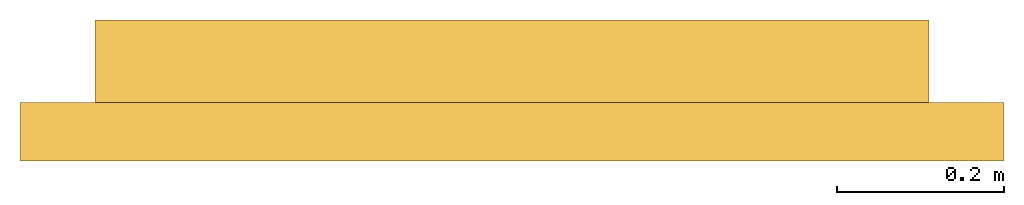
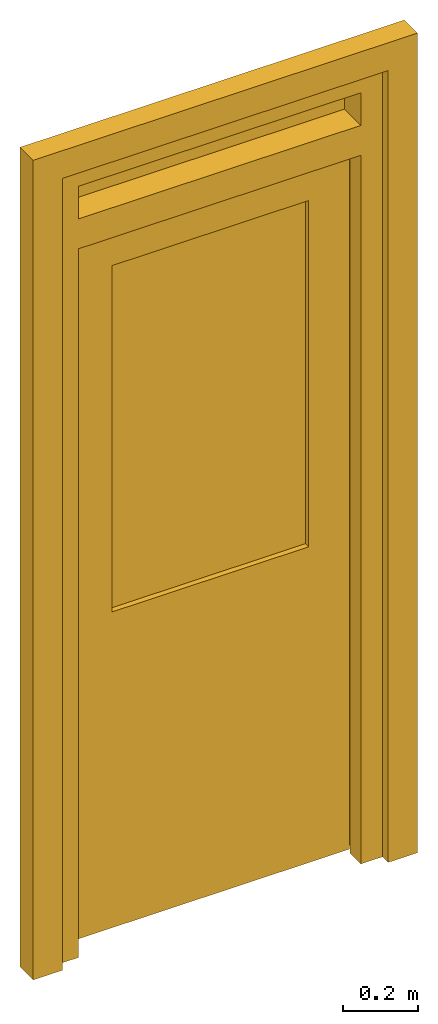
# One storey: 2 doors.
"""IFC4 building model written with IfcOpenShell, lengths in millimetres."""

from ifc_helpers import new_model, entity, si_unit, converted_unit, frame, origin_with_axes, origin_2d_with_axis, place, context, subcontext, project, spatial, polygons, source, transform, mapped, type_object, type_shapes, element, save


model = new_model("IFC4")

# Units and contexts
model_context = context("Model", 3, precision=1e-05, world=origin_with_axes())
plan_context = context("Plan", 2, precision=1e-05, world=origin_2d_with_axis())
body_context = subcontext(model_context, "Body", "Model", "MODEL_VIEW")
ifc_project = project(units=[si_unit("VOLUMEUNIT", "CUBIC_METRE"), si_unit("LENGTHUNIT", "METRE", prefix="MILLI"), converted_unit("PLANEANGLEUNIT", "degree", entity("IfcReal", 0.0174532925199433), si_unit("PLANEANGLEUNIT", "RADIAN"), dimensions=[0, 0, 0, 0, 0, 0, 0]), si_unit("AREAUNIT", "SQUARE_METRE")], contexts=[model_context, plan_context])

# Site, building, storey
site_placement = place(None, origin_with_axes())
site = spatial("IfcSite", under=ifc_project, at=site_placement)
building_placement = place(site_placement, origin_with_axes())
building = spatial("IfcBuilding", under=site, at=building_placement, Name="Building")
storey_placement = place(building_placement, origin_with_axes())
storey = spatial("IfcBuildingStorey", under=building, at=storey_placement, Name="Storey")

# Doors
door_type_1 = type_object("IfcDoorType", Name="D-1000x2570 T", OperationType="NOTDEFINED", PredefinedType="DOOR")
shared_shape_1 = source(origin_with_axes(), body_context, "Body", "Tessellation", [
    polygons([(-933.000061035156, -138.999938964844, -6.07588299317285e-06), (-1000.00006103516, -138.999938964844, -6.07588299317285e-06), (-933.000061035156, -139.000061035156, 2300.0), (-67.0000305175781, -139.000061035156, 2300.0), (-67.0000305175781, -138.999938964844, -6.07588299317285e-06), (0.0, -138.999938964844, -6.07588299317285e-06), (0.0, -139.000061035156, 2396.99975585938), (-1000.00006103516, -139.000061035156, 2396.99975585938), (-950.000122070312, 4.73394320579246e-05, 1.15221078663373e-13), (-950.000122070312, -4.73394320579246e-05, 2316.99951171875), (-1000.00006103516, 5.02680923091248e-05, 2.43237044004682e-13), (-1000.00006103516, -5.02680923091248e-05, 2396.99975585938), (0.0, -5.02680923091248e-05, 2396.99975585938), (0.0, 5.02680923091248e-05, 2.43237044004682e-13), (-50.0000686645508, 4.73394320579246e-05, 1.15221078663373e-13), (-50.0000686645508, -4.73394393338822e-05, 2233.00024414062), (-50.0000686645508, -4.73394320579246e-05, 2316.99951171875), (-933.000061035156, -4.73394320579246e-05, 2316.99951171875), (-933.000061035156, -82.0000457763672, 2300.0), (-67.0000305175781, -82.0000457763672, 2300.0), (-933.000061035156, -82.0000457763672, -3.58433749170217e-06), (-950.000122070312, -82.0000457763672, -3.58433749170217e-06), (-67.0000305175781, -82.0000457763672, -3.58433749170217e-06), (-50.0000686645508, -82.0000457763672, -3.58433749170217e-06), (-950.000122070312, -82.0000457763672, 2316.99951171875), (-933.000061035156, -82.0000457763672, 2316.99951171875), (-50.0000686645508, -82.0000457763672, 2316.99951171875), (-50.0000686645508, -82.0000457763672, 2233.00024414062), (-198.000061035156, -34.9999504089355, 1044.99987792969), (-198.000061035156, -88.9999542236328, 1044.99987792969), (-198.000061035156, -89.0000305175781, 2168.99975585938), (-198.000061035156, -35.0000381469727, 2168.99975585938), (-56.0000495910645, -74.0000381469727, 2310.0), (-56.0000495910645, -35.0000419616699, 2310.0), (-944.0, -35.0000419616699, 2310.0), (-944.0, -74.0000381469727, 2310.0), (-56.0000495910645, -73.9999465942383, 19.9999732971191), (-56.0000495910645, -34.9999465942383, 19.9999752044678), (-944.0, -34.9999465942383, 19.9999752044678), (-944.0, -73.9999465942383, 19.9999732971191), (-927.000061035156, -73.9999465942383, 19.9999732971191), (-927.000061035156, -74.0000381469727, 2293.0), (-73.0000686645508, -74.0000381469727, 2293.0), (-73.0000686645508, -73.9999465942383, 19.9999732971191), (-802.000061035156, -34.9999504089355, 1044.99987792969), (-802.000061035156, -88.9999542236328, 1044.99987792969), (-73.0000686645508, -88.9999465942383, 19.9999732971191), (-73.0000686645508, -89.0000381469727, 2293.0), (-927.000061035156, -89.0000381469727, 2293.0), (-927.000061035156, -88.9999465942383, 19.9999732971191), (-802.000061035156, -89.0000305175781, 2168.99975585938), (-802.000061035156, -35.0000381469727, 2168.99975585938), (-802.000061035156, -51.9999313354492, 1044.99987792969), (-198.000061035156, -51.9999313354492, 1044.99987792969), (-802.000061035156, -51.9999618530273, 2198.99975585938), (-198.000061035156, -51.9999618530273, 2198.99975585938), (-802.000061035156, -71.9999542236328, 2198.99975585938), (-802.000061035156, -71.9999237060547, 1044.99987792969), (-198.000061035156, -71.9999237060547, 1044.99987792969), (-198.000061035156, -71.9999542236328, 2198.99975585938), (-1000.00006103516, 0.0, 2396.99975585938), (-933.000061035156, 0.0, 2396.99975585938), (-1000.00006103516, 0.0, 2502.99975585938), (-933.000061035156, 0.0, 2502.99975585938), (-1000.00006103516, -139.000061035156, 2502.99975585938), (-1000.00006103516, -139.000061035156, 2396.99975585938), (-933.000061035156, -139.000061035156, 2396.99975585938), (-933.000061035156, -139.000061035156, 2502.99975585938), (-933.000061035156, 0.0, 2569.99975585938), (-1000.00006103516, 0.0, 2569.99975585938), (-933.000061035156, -139.000061035156, 2569.99975585938), (-1000.00006103516, -139.000061035156, 2569.99975585938), (0.0, -139.000061035156, 2502.99975585938), (0.0, 0.0, 2502.99975585938), (0.0, -139.000061035156, 2569.99975585938), (0.0, 0.0, 2569.99975585938), (0.0, 0.0, 2502.99975585938), (-67.0000305175781, 0.0, 2502.99975585938), (0.0, -139.000061035156, 2502.99975585938), (-67.0000305175781, -139.000061035156, 2502.99975585938), (0.0, 0.0, 2396.99975585938), (-67.0000305175781, 0.0, 2396.99975585938), (0.0, -139.000061035156, 2396.99975585938), (-67.0000305175781, -139.000061035156, 2396.99975585938), (-933.000061035156, -31.9999580383301, 2396.99975585938), (-67.0000305175781, -31.9999580383301, 2396.99975585938), (-933.000061035156, -31.9999580383301, 2502.99975585938), (-67.0000305175781, -31.9999580383301, 2502.99975585938), (-933.000061035156, -51.9999694824219, 2502.99975585938), (-933.000061035156, -51.9999694824219, 2396.99975585938), (-67.0000305175781, -51.9999694824219, 2396.99975585938), (-67.0000305175781, -51.9999694824219, 2502.99975585938)], [[[6, 5, 23, 24, 15, 14]], [[6, 7, 8, 2, 1, 3, 4, 5]], [[4, 3, 19, 20]], [[17, 18, 10, 9, 11, 12, 13, 14, 15, 16]], [[2, 11, 9, 22, 21, 1]], [[4, 20, 23, 5]], [[12, 8, 7, 13]], [[22, 25, 26, 27, 28, 24, 23, 20, 19, 21]], [[18, 17, 27, 26, 25, 10]], [[13, 7, 6, 14]], [[16, 15, 24, 28, 27, 17]], [[9, 10, 25, 22]], [[1, 21, 19, 3]], [[12, 11, 2, 8]], [[61, 63, 64, 62]], [[66, 67, 68, 65]], [[61, 62, 67, 66]], [[62, 64, 68, 67]], [[63, 61, 66, 65]], [[63, 65, 72, 70]], [[69, 70, 72, 71, 75, 76]], [[73, 74, 76, 75]], [[77, 79, 80, 78]], [[81, 82, 84, 83]], [[78, 80, 84, 82]], [[77, 78, 82, 81]], [[79, 77, 81, 83]], [[80, 79, 83, 84]], [[68, 73, 75, 71, 72, 65]], [[64, 63, 70, 69, 76, 74]], [[64, 74, 73, 68, 65, 63]], [[73, 65, 68]], [[63, 74, 64]], [[86, 88, 92, 91]], [[87, 85, 90, 89]], [[88, 87, 89, 92]], [[85, 86, 91, 90]]], closed=False),
    polygons([(-933.000061035156, -138.999938964844, -6.07588299317285e-06), (-1000.00006103516, -138.999938964844, -6.07588299317285e-06), (-933.000061035156, -139.000061035156, 2300.0), (-67.0000305175781, -139.000061035156, 2300.0), (-67.0000305175781, -138.999938964844, -6.07588299317285e-06), (0.0, -138.999938964844, -6.07588299317285e-06), (0.0, -139.000061035156, 2396.99975585938), (-1000.00006103516, -139.000061035156, 2396.99975585938), (-950.000122070312, 4.73394320579246e-05, 1.15221078663373e-13), (-950.000122070312, -4.73394320579246e-05, 2316.99951171875), (-1000.00006103516, 5.02680923091248e-05, 2.43237044004682e-13), (-1000.00006103516, -5.02680923091248e-05, 2396.99975585938), (0.0, -5.02680923091248e-05, 2396.99975585938), (0.0, 5.02680923091248e-05, 2.43237044004682e-13), (-50.0000686645508, 4.73394320579246e-05, 1.15221078663373e-13), (-50.0000686645508, -4.73394393338822e-05, 2233.00024414062), (-50.0000686645508, -4.73394320579246e-05, 2316.99951171875), (-933.000061035156, -4.73394320579246e-05, 2316.99951171875), (-933.000061035156, -82.0000457763672, 2300.0), (-67.0000305175781, -82.0000457763672, 2300.0), (-933.000061035156, -82.0000457763672, -3.58433749170217e-06), (-950.000122070312, -82.0000457763672, -3.58433749170217e-06), (-67.0000305175781, -82.0000457763672, -3.58433749170217e-06), (-50.0000686645508, -82.0000457763672, -3.58433749170217e-06), (-950.000122070312, -82.0000457763672, 2316.99951171875), (-933.000061035156, -82.0000457763672, 2316.99951171875), (-50.0000686645508, -82.0000457763672, 2316.99951171875), (-50.0000686645508, -82.0000457763672, 2233.00024414062), (-198.000061035156, -34.9999504089355, 1044.99987792969), (-198.000061035156, -88.9999542236328, 1044.99987792969), (-198.000061035156, -89.0000305175781, 2168.99975585938), (-198.000061035156, -35.0000381469727, 2168.99975585938), (-56.0000495910645, -74.0000381469727, 2310.0), (-56.0000495910645, -35.0000419616699, 2310.0), (-944.0, -35.0000419616699, 2310.0), (-944.0, -74.0000381469727, 2310.0), (-56.0000495910645, -73.9999465942383, 19.9999732971191), (-56.0000495910645, -34.9999465942383, 19.9999752044678), (-944.0, -34.9999465942383, 19.9999752044678), (-944.0, -73.9999465942383, 19.9999732971191), (-927.000061035156, -73.9999465942383, 19.9999732971191), (-927.000061035156, -74.0000381469727, 2293.0), (-73.0000686645508, -74.0000381469727, 2293.0), (-73.0000686645508, -73.9999465942383, 19.9999732971191), (-802.000061035156, -34.9999504089355, 1044.99987792969), (-802.000061035156, -88.9999542236328, 1044.99987792969), (-73.0000686645508, -88.9999465942383, 19.9999732971191), (-73.0000686645508, -89.0000381469727, 2293.0), (-927.000061035156, -89.0000381469727, 2293.0), (-927.000061035156, -88.9999465942383, 19.9999732971191), (-802.000061035156, -89.0000305175781, 2168.99975585938), (-802.000061035156, -35.0000381469727, 2168.99975585938), (-802.000061035156, -51.9999313354492, 1044.99987792969), (-198.000061035156, -51.9999313354492, 1044.99987792969), (-802.000061035156, -51.9999618530273, 2198.99975585938), (-198.000061035156, -51.9999618530273, 2198.99975585938), (-802.000061035156, -71.9999542236328, 2198.99975585938), (-802.000061035156, -71.9999237060547, 1044.99987792969), (-198.000061035156, -71.9999237060547, 1044.99987792969), (-198.000061035156, -71.9999542236328, 2198.99975585938), (-1000.00006103516, 0.0, 2396.99975585938), (-933.000061035156, 0.0, 2396.99975585938), (-1000.00006103516, 0.0, 2502.99975585938), (-933.000061035156, 0.0, 2502.99975585938), (-1000.00006103516, -139.000061035156, 2502.99975585938), (-1000.00006103516, -139.000061035156, 2396.99975585938), (-933.000061035156, -139.000061035156, 2396.99975585938), (-933.000061035156, -139.000061035156, 2502.99975585938), (-933.000061035156, 0.0, 2569.99975585938), (-1000.00006103516, 0.0, 2569.99975585938), (-933.000061035156, -139.000061035156, 2569.99975585938), (-1000.00006103516, -139.000061035156, 2569.99975585938), (0.0, -139.000061035156, 2502.99975585938), (0.0, 0.0, 2502.99975585938), (0.0, -139.000061035156, 2569.99975585938), (0.0, 0.0, 2569.99975585938), (0.0, 0.0, 2502.99975585938), (-67.0000305175781, 0.0, 2502.99975585938), (0.0, -139.000061035156, 2502.99975585938), (-67.0000305175781, -139.000061035156, 2502.99975585938), (0.0, 0.0, 2396.99975585938), (-67.0000305175781, 0.0, 2396.99975585938), (0.0, -139.000061035156, 2396.99975585938), (-67.0000305175781, -139.000061035156, 2396.99975585938), (-933.000061035156, -31.9999580383301, 2396.99975585938), (-67.0000305175781, -31.9999580383301, 2396.99975585938), (-933.000061035156, -31.9999580383301, 2502.99975585938), (-67.0000305175781, -31.9999580383301, 2502.99975585938), (-933.000061035156, -51.9999694824219, 2502.99975585938), (-933.000061035156, -51.9999694824219, 2396.99975585938), (-67.0000305175781, -51.9999694824219, 2396.99975585938), (-67.0000305175781, -51.9999694824219, 2502.99975585938)], [[[51, 46, 45, 52]], [[40, 39, 38, 37, 44, 47, 50, 41]], [[31, 32, 29, 30]], [[31, 48, 49, 51]], [[34, 32, 52, 35]], [[36, 35, 39, 40]], [[36, 33, 34, 35]], [[34, 33, 37, 38]], [[41, 42, 36, 40]], [[43, 48, 47, 44]], [[49, 48, 43, 42]], [[30, 29, 45, 46]], [[37, 33, 43, 44]], [[46, 51, 49, 50, 47, 48, 31, 30]], [[49, 42, 41, 50]], [[43, 33, 36, 42]], [[34, 38, 39, 35, 52, 45, 29, 32]], [[31, 51, 52, 32]]], closed=False),
    polygons([(-933.000061035156, -138.999938964844, -6.07588299317285e-06), (-1000.00006103516, -138.999938964844, -6.07588299317285e-06), (-933.000061035156, -139.000061035156, 2300.0), (-67.0000305175781, -139.000061035156, 2300.0), (-67.0000305175781, -138.999938964844, -6.07588299317285e-06), (0.0, -138.999938964844, -6.07588299317285e-06), (0.0, -139.000061035156, 2396.99975585938), (-1000.00006103516, -139.000061035156, 2396.99975585938), (-950.000122070312, 4.73394320579246e-05, 1.15221078663373e-13), (-950.000122070312, -4.73394320579246e-05, 2316.99951171875), (-1000.00006103516, 5.02680923091248e-05, 2.43237044004682e-13), (-1000.00006103516, -5.02680923091248e-05, 2396.99975585938), (0.0, -5.02680923091248e-05, 2396.99975585938), (0.0, 5.02680923091248e-05, 2.43237044004682e-13), (-50.0000686645508, 4.73394320579246e-05, 1.15221078663373e-13), (-50.0000686645508, -4.73394393338822e-05, 2233.00024414062), (-50.0000686645508, -4.73394320579246e-05, 2316.99951171875), (-933.000061035156, -4.73394320579246e-05, 2316.99951171875), (-933.000061035156, -82.0000457763672, 2300.0), (-67.0000305175781, -82.0000457763672, 2300.0), (-933.000061035156, -82.0000457763672, -3.58433749170217e-06), (-950.000122070312, -82.0000457763672, -3.58433749170217e-06), (-67.0000305175781, -82.0000457763672, -3.58433749170217e-06), (-50.0000686645508, -82.0000457763672, -3.58433749170217e-06), (-950.000122070312, -82.0000457763672, 2316.99951171875), (-933.000061035156, -82.0000457763672, 2316.99951171875), (-50.0000686645508, -82.0000457763672, 2316.99951171875), (-50.0000686645508, -82.0000457763672, 2233.00024414062), (-198.000061035156, -34.9999504089355, 1044.99987792969), (-198.000061035156, -88.9999542236328, 1044.99987792969), (-198.000061035156, -89.0000305175781, 2168.99975585938), (-198.000061035156, -35.0000381469727, 2168.99975585938), (-56.0000495910645, -74.0000381469727, 2310.0), (-56.0000495910645, -35.0000419616699, 2310.0), (-944.0, -35.0000419616699, 2310.0), (-944.0, -74.0000381469727, 2310.0), (-56.0000495910645, -73.9999465942383, 19.9999732971191), (-56.0000495910645, -34.9999465942383, 19.9999752044678), (-944.0, -34.9999465942383, 19.9999752044678), (-944.0, -73.9999465942383, 19.9999732971191), (-927.000061035156, -73.9999465942383, 19.9999732971191), (-927.000061035156, -74.0000381469727, 2293.0), (-73.0000686645508, -74.0000381469727, 2293.0), (-73.0000686645508, -73.9999465942383, 19.9999732971191), (-802.000061035156, -34.9999504089355, 1044.99987792969), (-802.000061035156, -88.9999542236328, 1044.99987792969), (-73.0000686645508, -88.9999465942383, 19.9999732971191), (-73.0000686645508, -89.0000381469727, 2293.0), (-927.000061035156, -89.0000381469727, 2293.0), (-927.000061035156, -88.9999465942383, 19.9999732971191), (-802.000061035156, -89.0000305175781, 2168.99975585938), (-802.000061035156, -35.0000381469727, 2168.99975585938), (-802.000061035156, -51.9999313354492, 1044.99987792969), (-198.000061035156, -51.9999313354492, 1044.99987792969), (-802.000061035156, -51.9999618530273, 2198.99975585938), (-198.000061035156, -51.9999618530273, 2198.99975585938), (-802.000061035156, -71.9999542236328, 2198.99975585938), (-802.000061035156, -71.9999237060547, 1044.99987792969), (-198.000061035156, -71.9999237060547, 1044.99987792969), (-198.000061035156, -71.9999542236328, 2198.99975585938), (-1000.00006103516, 0.0, 2396.99975585938), (-933.000061035156, 0.0, 2396.99975585938), (-1000.00006103516, 0.0, 2502.99975585938), (-933.000061035156, 0.0, 2502.99975585938), (-1000.00006103516, -139.000061035156, 2502.99975585938), (-1000.00006103516, -139.000061035156, 2396.99975585938), (-933.000061035156, -139.000061035156, 2396.99975585938), (-933.000061035156, -139.000061035156, 2502.99975585938), (-933.000061035156, 0.0, 2569.99975585938), (-1000.00006103516, 0.0, 2569.99975585938), (-933.000061035156, -139.000061035156, 2569.99975585938), (-1000.00006103516, -139.000061035156, 2569.99975585938), (0.0, -139.000061035156, 2502.99975585938), (0.0, 0.0, 2502.99975585938), (0.0, -139.000061035156, 2569.99975585938), (0.0, 0.0, 2569.99975585938), (0.0, 0.0, 2502.99975585938), (-67.0000305175781, 0.0, 2502.99975585938), (0.0, -139.000061035156, 2502.99975585938), (-67.0000305175781, -139.000061035156, 2502.99975585938), (0.0, 0.0, 2396.99975585938), (-67.0000305175781, 0.0, 2396.99975585938), (0.0, -139.000061035156, 2396.99975585938), (-67.0000305175781, -139.000061035156, 2396.99975585938), (-933.000061035156, -31.9999580383301, 2396.99975585938), (-67.0000305175781, -31.9999580383301, 2396.99975585938), (-933.000061035156, -31.9999580383301, 2502.99975585938), (-67.0000305175781, -31.9999580383301, 2502.99975585938), (-933.000061035156, -51.9999694824219, 2502.99975585938), (-933.000061035156, -51.9999694824219, 2396.99975585938), (-67.0000305175781, -51.9999694824219, 2396.99975585938), (-67.0000305175781, -51.9999694824219, 2502.99975585938)], [[[53, 55, 56, 54]], [[56, 60, 59, 54]], [[54, 59, 58, 53]], [[59, 60, 57, 58]], [[55, 57, 60, 56]], [[55, 53, 58, 57]], [[85, 87, 88, 86]], [[90, 91, 92, 89]]], closed=False),
])
type_shapes(door_type_1, [shared_shape_1])
door_1_placement = place(storey_placement, frame((0.0, 0.0, 6.07588335199694e-06), z_axis=(0.0, 0.0, 1.0), x_axis=(0.999999999999788, 6.51682739771648e-07, 0.0)))
element("IfcDoor", 1, at=door_1_placement, inside=storey, type_object=door_type_1, Name="Door", context=body_context, shape_type="MappedRepresentation", body=[
    mapped(shared_shape_1, transform((0.0, 0.0, 0.0), x_axis=(1.0, 0.0, 0.0), y_axis=(0.0, 1.0, 0.0), z_axis=(0.0, 0.0, 1.0), scale=1.0)),
])
door_type_2 = type_object("IfcDoorType", Name="DF-1000x2570 T", OperationType="NOTDEFINED", PredefinedType="DOOR")
shared_shape_2 = source(origin_with_axes(), body_context, "Body", "Tessellation", [
    polygons([(-1090.00012207031, -168.999938964844, 0.0), (-1000.00006103516, -168.999938964844, 0.0), (-1090.00012207031, -98.9999542236328, 0.0), (-1000.00006103516, -98.9999542236328, 0.0), (-1090.00012207031, -98.9999542236328, 2659.99975585938), (-1090.00012207031, -168.999938964844, 2659.99975585938), (89.9999084472656, -168.999938964844, 2659.99975585938), (89.9999084472656, -98.9999542236328, 2659.99975585938), (-1000.00006103516, -98.9999542236328, 2569.99975585938), (-1000.00006103516, -168.999938964844, 2569.99975585938), (-1090.00012207031, -168.999938964844, 2569.99975585938), (-1090.00012207031, -98.9999542236328, 2569.99975585938), (89.9999084472656, -98.9999542236328, 2569.99975585938), (-1090.00012207031, -168.999938964844, 2569.99975585938), (89.9999084472656, -168.999938964844, 2569.99975585938), (-1090.00012207031, -98.9999542236328, 2569.99975585938), (-0.000119209282274824, -168.999938964844, 0.0), (-0.000119209282274824, -98.9999542236328, 0.0), (-0.000119209282274824, -98.9999542236328, 2569.99975585938), (-0.000119209282274824, -168.999938964844, 2569.99975585938), (89.9999084472656, -168.999938964844, 0.0), (89.9999084472656, -98.9999542236328, 0.0), (89.9999084472656, -168.999938964844, 2569.99975585938), (89.9999084472656, -98.9999542236328, 2569.99975585938)], [[[1, 3, 4, 2]], [[6, 7, 8, 5]], [[15, 13, 8, 7]], [[16, 14, 6, 5]], [[13, 16, 5, 8]], [[14, 15, 7, 6]], [[1, 2, 10, 11]], [[4, 3, 12, 9]], [[3, 1, 11, 12]], [[2, 4, 9, 10]], [[11, 15, 14]], [[9, 16, 13]], [[12, 14, 16]], [[10, 9, 13, 15]], [[17, 20, 19, 18]], [[21, 22, 24, 23]], [[18, 19, 24, 22]], [[17, 18, 22, 21]], [[19, 20, 23, 24]], [[20, 17, 21, 23]], [[11, 10, 15]], [[9, 12, 16]], [[12, 11, 14]]], closed=True),
])
type_shapes(door_type_2, [shared_shape_2])
door_2_placement = place(storey_placement, frame((0.0, 0.0, 0.0), z_axis=(0.0, 0.0, 1.0), x_axis=(0.999999999999788, 6.51682739771648e-07, 0.0)))
element("IfcDoor", 2, at=door_2_placement, inside=storey, type_object=door_type_2, Name="Door", context=body_context, shape_type="MappedRepresentation", body=[
    mapped(shared_shape_2, transform((0.0, 0.0, 0.0), x_axis=(1.0, 0.0, 0.0), y_axis=(0.0, 1.0, 0.0), z_axis=(0.0, 0.0, 1.0), scale=1.0)),
])

save(model, "model.ifc")
